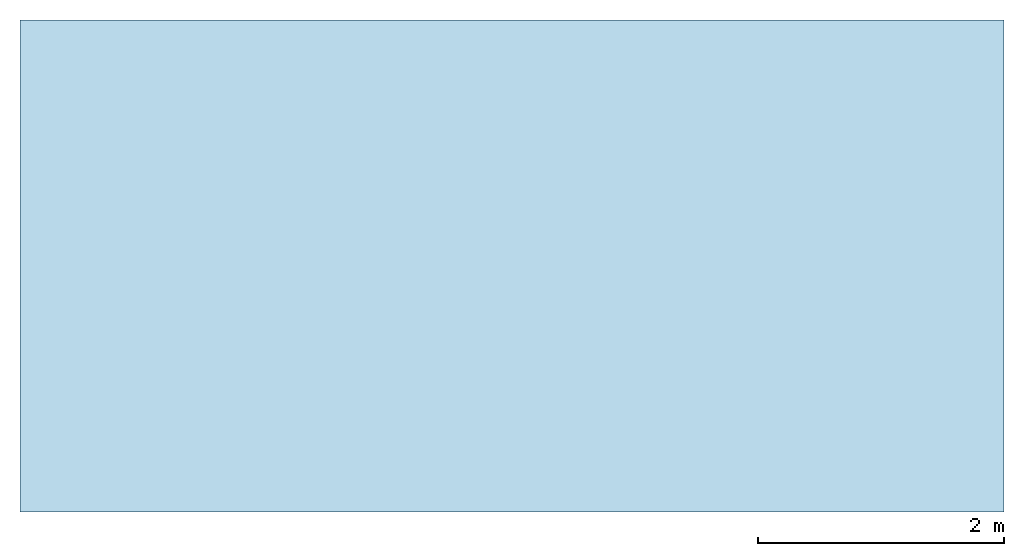
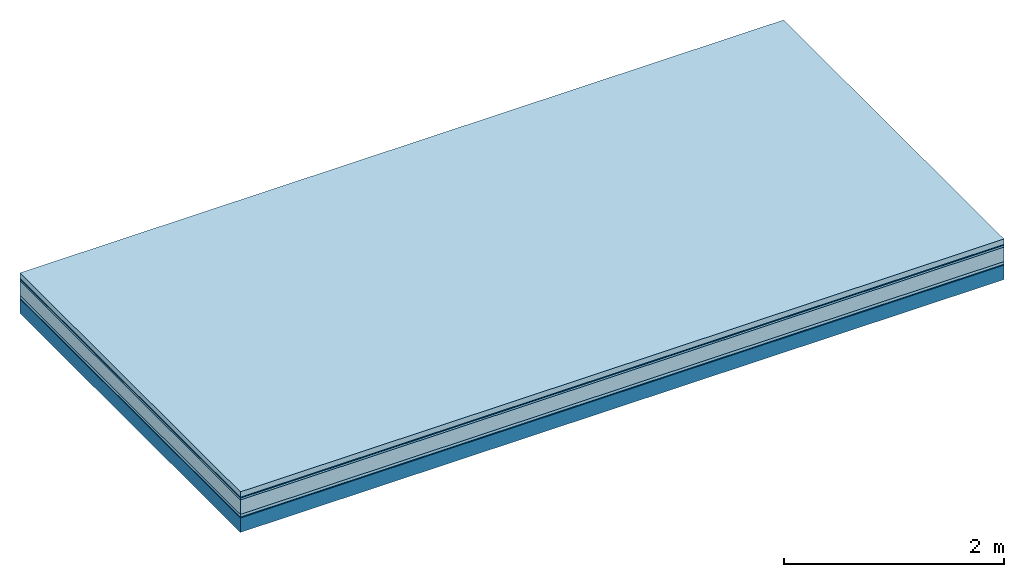
# One storey: 6 plates, 1 member, 1 element without a shape of its own.
"""IFC4 building model written with IfcOpenShell, lengths in metres."""

from ifc_helpers import new_model, si_unit, derived_unit, direction, frame, frame_2d, origin, origin_with_axes, place, context, project, spatial, rectangle, extrude, material, layer, layer_set, type_object, element, aggregate, save


model = new_model("IFC4")

# Units and contexts
plan_context = context("Plan", 3, precision=1e-05, world=origin(), true_north=direction((0.0, 1.0)))
model_context = context("Model", 3, precision=1e-05, world=origin(), true_north=direction((0.0, 1.0)))
ifc_project = project(units=[si_unit("LENGTHUNIT", "METRE"), derived_unit("SOUNDPRESSUREUNIT", [(si_unit("PRESSUREUNIT", "PASCAL", prefix="MICRO"), 0)]), si_unit("ENERGYUNIT", "JOULE", prefix="MEGA"), si_unit("MASSUNIT", "GRAM", prefix="KILO"), derived_unit("THERMALTRANSMITTANCEUNIT", [(si_unit("POWERUNIT", "WATT"), 1), (si_unit("AREAUNIT", "SQUARE_METRE"), -1), (si_unit("THERMODYNAMICTEMPERATUREUNIT", "KELVIN"), -1)]), derived_unit("AREADENSITYUNIT", [(si_unit("MASSUNIT", "GRAM", prefix="KILO"), 1), (si_unit("AREAUNIT", "SQUARE_METRE"), -1)]), derived_unit("USERDEFINED", [(si_unit("ENERGYUNIT", "JOULE", prefix="MEGA"), 1), (si_unit("AREAUNIT", "SQUARE_METRE"), -1)])], contexts=[plan_context, model_context])

# Site, building, storey
site = spatial("IfcSite", under=ifc_project)
building_placement = place(None, origin())
building = spatial("IfcBuilding", under=site, at=building_placement)
storey_placement = place(building_placement, origin())
storey = spatial("IfcBuildingStorey", under=building, at=storey_placement)

# Slab, member, plates
ifc_material_1 = material(Name="clay", Category="02.004")
ifc_layer_1 = layer(ifc_material_1, 0.06, Name="Use and protection layer 2")
ifc_material_2 = material(Name="Protective layer", Category="09.007")
ifc_layer_2 = layer(ifc_material_2, 0.01, Name="Use and protection layer 1")
ifc_material_3 = material(Name="Bituminous", Category="09.003")
ifc_layer_3 = layer(ifc_material_3, 0.02, Name="Seal")
ifc_material_4 = material(Category="10.006")
ifc_layer_4 = layer(ifc_material_4, 0.16, Name="Exterior insulation layer 2")
ifc_material_5 = material(Name="(034) 25 boards", Category="10.004")
ifc_layer_5 = layer(ifc_material_5, 0.03, Name="Exterior insulation layer 1")
ifc_material_6 = material(Name="Vapor-permeable barrier", Category="09.006")
ifc_layer_6 = layer(ifc_material_6, 0.01, Name="layer / temporary roof")
ifc_material_7 = material(Name="no composite action")
ifc_layer_7 = layer(ifc_material_7, 0.0, Name="Bond")
ifc_layer_8 = layer(None, 0.16, Name="Support")
ifc_layer_set = layer_set([ifc_layer_1, ifc_layer_2, ifc_layer_3, ifc_layer_4, ifc_layer_5, ifc_layer_6, ifc_layer_7, ifc_layer_8])
slab_type = type_object("IfcSlabType", Name="F0066", PredefinedType="NOTDEFINED", material=ifc_layer_set)
slab_placement = place(None, frame((0.0, 0.0, 0.0), z_axis=(0.0, 0.0, -1.0), x_axis=(1.0, 0.0, 0.0)))
slab = element("IfcSlab", 1, at=slab_placement, inside=storey, type_object=slab_type, material=ifc_layer_set, Name="Slab #1")
ifc_material_8 = material(Name="Solid timber panel")
member_placement = place(slab_placement, origin())
member = element("IfcMember", 2, at=member_placement, material=ifc_material_8, Name="Support", context=plan_context, shape_type="SweptSolid", body=[
    extrude(rectangle(XDim=1.0, YDim=0.16, at=frame_2d((0.5, 0.08), x_axis=(1.0, 0.0))), frame((0.0, 4.0, 0.29), z_axis=(0.0, -1.0, 0.0), x_axis=(1.0, 0.0, 0.0)), (0.0, 0.0, 1.0), 4.0),
    extrude(rectangle(XDim=1.0, YDim=0.16, at=frame_2d((0.5, 0.08), x_axis=(1.0, 0.0))), frame((1.0, 4.0, 0.29), z_axis=(0.0, -1.0, 0.0), x_axis=(1.0, 0.0, 0.0)), (0.0, 0.0, 1.0), 4.0),
    extrude(rectangle(XDim=1.0, YDim=0.16, at=frame_2d((0.5, 0.08), x_axis=(1.0, 0.0))), frame((2.0, 4.0, 0.29), z_axis=(0.0, -1.0, 0.0), x_axis=(1.0, 0.0, 0.0)), (0.0, 0.0, 1.0), 4.0),
    extrude(rectangle(XDim=1.0, YDim=0.16, at=frame_2d((0.5, 0.08), x_axis=(1.0, 0.0))), frame((3.0, 4.0, 0.29), z_axis=(0.0, -1.0, 0.0), x_axis=(1.0, 0.0, 0.0)), (0.0, 0.0, 1.0), 4.0),
    extrude(rectangle(XDim=1.0, YDim=0.16, at=frame_2d((0.5, 0.08), x_axis=(1.0, 0.0))), frame((4.0, 4.0, 0.29), z_axis=(0.0, -1.0, 0.0), x_axis=(1.0, 0.0, 0.0)), (0.0, 0.0, 1.0), 4.0),
    extrude(rectangle(XDim=1.0, YDim=0.16, at=frame_2d((0.5, 0.08), x_axis=(1.0, 0.0))), frame((5.0, 4.0, 0.29), z_axis=(0.0, -1.0, 0.0), x_axis=(1.0, 0.0, 0.0)), (0.0, 0.0, 1.0), 4.0),
    extrude(rectangle(XDim=1.0, YDim=0.16, at=frame_2d((0.5, 0.08), x_axis=(1.0, 0.0))), frame((6.0, 4.0, 0.29), z_axis=(0.0, -1.0, 0.0), x_axis=(1.0, 0.0, 0.0)), (0.0, 0.0, 1.0), 4.0),
    extrude(rectangle(XDim=1.0, YDim=0.16, at=frame_2d((0.5, 0.08), x_axis=(1.0, 0.0))), frame((7.0, 4.0, 0.29), z_axis=(0.0, -1.0, 0.0), x_axis=(1.0, 0.0, 0.0)), (0.0, 0.0, 1.0), 4.0),
])
plate_1_placement = place(slab_placement, origin())
plate_1 = element("IfcPlate", 3, at=plate_1_placement, material=ifc_material_1, Name="Use and protection layer 2", context=plan_context, shape_type="SweptSolid", body=[
    extrude(rectangle(XDim=8.0, YDim=4.0, at=frame_2d((4.0, 2.0), x_axis=(1.0, 0.0))), origin_with_axes(), (0.0, 0.0, 1.0), 0.06),
])
plate_2_placement = place(slab_placement, origin())
plate_2 = element("IfcPlate", 4, at=plate_2_placement, material=ifc_material_2, Name="Use and protection layer 1", context=plan_context, shape_type="SweptSolid", body=[
    extrude(rectangle(XDim=8.0, YDim=4.0, at=frame_2d((4.0, 2.0), x_axis=(1.0, 0.0))), frame((0.0, 0.0, 0.06), z_axis=(0.0, 0.0, 1.0), x_axis=(1.0, 0.0, 0.0)), (0.0, 0.0, 1.0), 0.01),
])
plate_3_placement = place(slab_placement, origin())
plate_3 = element("IfcPlate", 5, at=plate_3_placement, material=ifc_material_3, Name="Seal", context=plan_context, shape_type="SweptSolid", body=[
    extrude(rectangle(XDim=8.0, YDim=4.0, at=frame_2d((4.0, 2.0), x_axis=(1.0, 0.0))), frame((0.0, 0.0, 0.07), z_axis=(0.0, 0.0, 1.0), x_axis=(1.0, 0.0, 0.0)), (0.0, 0.0, 1.0), 0.02),
])
plate_4_placement = place(slab_placement, origin())
plate_4 = element("IfcPlate", 6, at=plate_4_placement, material=ifc_material_4, Name="Exterior insulation layer 2", context=plan_context, shape_type="SweptSolid", body=[
    extrude(rectangle(XDim=8.0, YDim=4.0, at=frame_2d((4.0, 2.0), x_axis=(1.0, 0.0))), frame((0.0, 0.0, 0.09), z_axis=(0.0, 0.0, 1.0), x_axis=(1.0, 0.0, 0.0)), (0.0, 0.0, 1.0), 0.16),
])
plate_5_placement = place(slab_placement, origin())
plate_5 = element("IfcPlate", 7, at=plate_5_placement, material=ifc_material_5, Name="Exterior insulation layer 1", context=plan_context, shape_type="SweptSolid", body=[
    extrude(rectangle(XDim=8.0, YDim=4.0, at=frame_2d((4.0, 2.0), x_axis=(1.0, 0.0))), frame((0.0, 0.0, 0.25), z_axis=(0.0, 0.0, 1.0), x_axis=(1.0, 0.0, 0.0)), (0.0, 0.0, 1.0), 0.03),
])
plate_6_placement = place(slab_placement, origin())
plate_6 = element("IfcPlate", 8, at=plate_6_placement, material=ifc_material_6, Name="layer / temporary roof", context=plan_context, shape_type="SweptSolid", body=[
    extrude(rectangle(XDim=8.0, YDim=4.0, at=frame_2d((4.0, 2.0), x_axis=(1.0, 0.0))), frame((0.0, 0.0, 0.28), z_axis=(0.0, 0.0, 1.0), x_axis=(1.0, 0.0, 0.0)), (0.0, 0.0, 1.0), 0.01),
])
aggregate(slab, [plate_1, plate_2, plate_3, plate_4, plate_5, plate_6, member])

save(model, "model.ifc")
